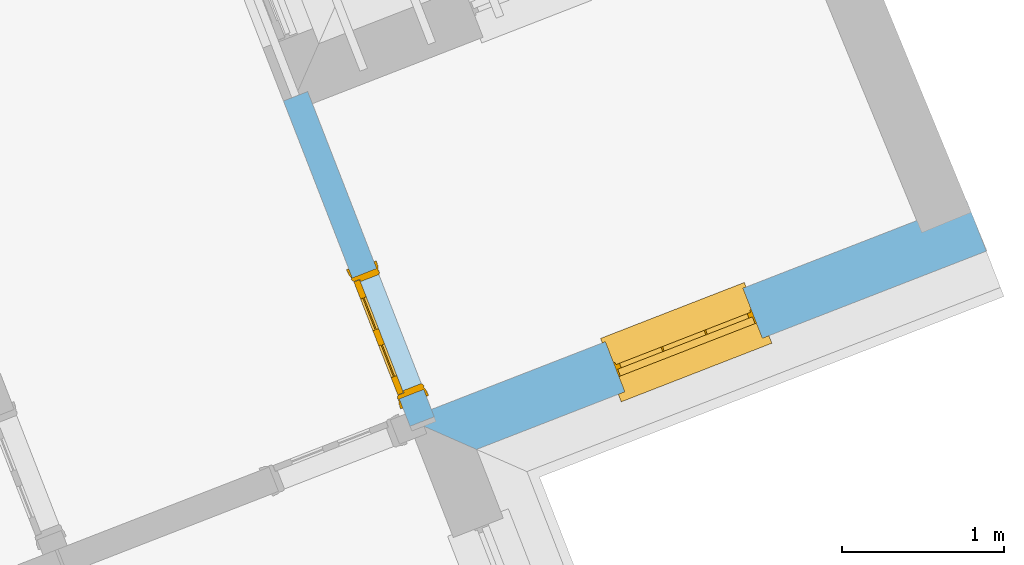
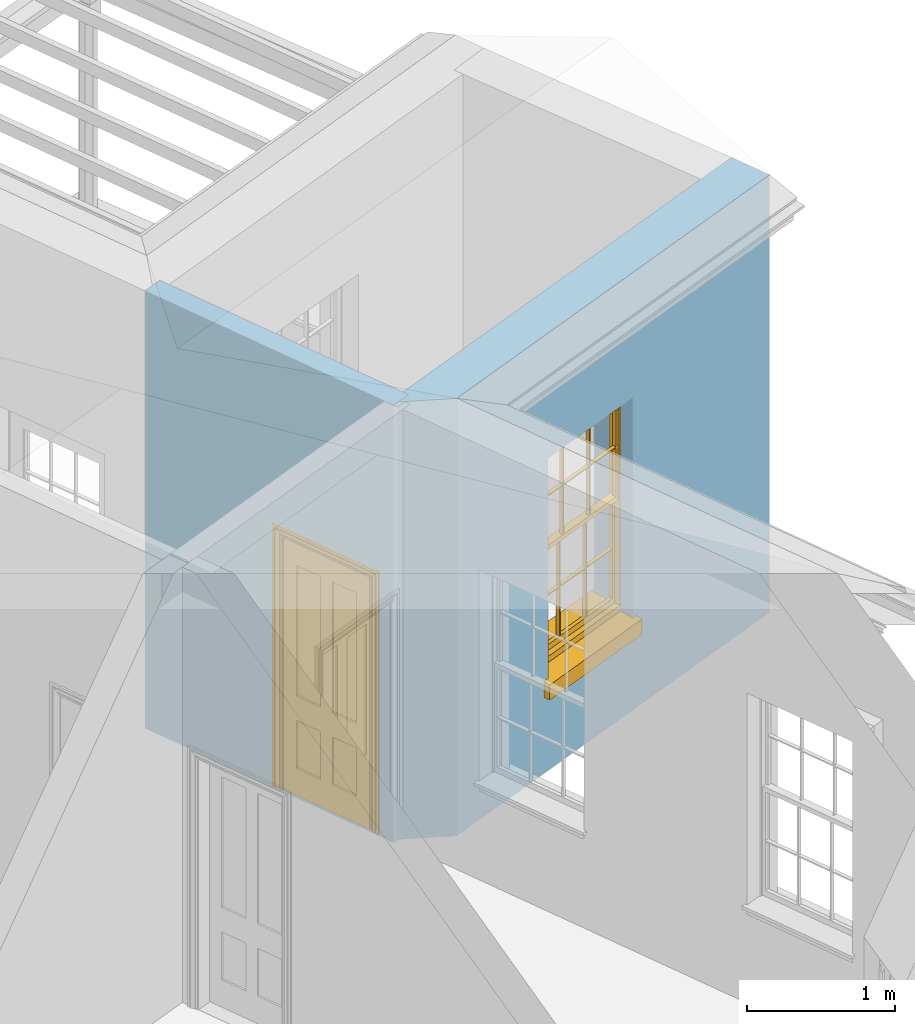
# One storey, part 7 of 11: 1 door, 1 window, 2 openings, plus 2 elements that do not belong to this part.
"""IFC2X3 building model written with IfcOpenShell, lengths in metres."""

from ifc_helpers import new_model, si_unit, frame, origin, place, context, subcontext, project, spatial, polyline, outline, extrude, faceted_brep, material, layer, layer_set, layer_usage, element, fill, save


model = new_model("IFC2X3")

# Units and contexts
model_context = context("Model", 3, world=origin())
body_context = subcontext(model_context, "Body", "Model", "MODEL_VIEW")
ifc_project = project(units=[si_unit("PLANEANGLEUNIT", "RADIAN"), si_unit("MASSUNIT", "GRAM", prefix="KILO"), si_unit("FORCEUNIT", "NEWTON", prefix="KILO"), si_unit("LENGTHUNIT", "METRE")], contexts=[model_context])

# Site, building, storey
site_placement = place(None, origin())
site = spatial("IfcSite", under=ifc_project, at=site_placement, CompositionType="ELEMENT")
building_placement = place(None, origin())
building = spatial("IfcBuilding", under=site, at=building_placement, Name="Building plot-3", CompositionType="ELEMENT")
storey_placement = place(None, frame((0.0, 0.0, 5.45)))
storey = spatial("IfcBuildingStorey", under=building, at=storey_placement, Name="Floor 1", CompositionType="ELEMENT", Elevation=5.45)

# Wall, opening, window
ifc_material_1 = material(Name="Masonry")
ifc_layer_1 = layer(ifc_material_1, 0.33, ventilated=False)
ifc_layer_set_1 = layer_set([ifc_layer_1], Name="My Wall")
ifc_layer_usage_1 = layer_usage(ifc_layer_set_1, "AXIS2", "NEGATIVE", 0.08)
wall_1_placement = place(storey_placement, origin())
wall_1 = element("IfcWallStandardCase", 1, at=wall_1_placement, inside=storey, material=ifc_layer_usage_1, Name="exterior", context=body_context, shape_type="SweptSolid", body=[
    extrude(outline(polyline([(41.1667504349144, 48.3334570792536), (41.5939403189539, 48.1455507116809), (44.7327190868894, 49.3665921650056), (44.613077328656, 49.6741402908117), (41.1667504349144, 48.3334570792536)])), origin(), (0.0, 0.0, 1.0), 3.6),
])
opening_1_placement = place(storey_placement, frame((0.0, 0.0, 0.75)))
opening_1 = element("IfcOpeningElement", 2, at=opening_1_placement, cuts=wall_1, Name="Opening", ObjectType="Opening", context=body_context, shape_type="SweptSolid", body=[
    extrude(outline(polyline([(42.5062950705178, 48.5004731366628), (43.3543823265284, 48.830394348761), (43.234740568295, 49.1379424745671), (42.3866533122844, 48.8080212624689), (42.5062950705178, 48.5004731366628)])), origin(), (0.0, 0.0, 1.0), 1.82),
])
window_placement = place(storey_placement, frame((42.4156573748864, 48.7334641410613, 0.75), z_axis=(0.0, 0.0, 1.0), x_axis=(0.848087256010643, 0.329921212098206, 0.0)))
window = element("IfcWindow", 3, at=window_placement, inside=storey, Name="toilet outside window", OverallHeight=1.82, OverallWidth=0.91, context=body_context, shape_type="Brep", held_by="IfcProductRepresentation", body=[
    faceted_brep([(0.033125, -0.105, 0.975209), (0.01, -0.105, 0.975209), (0.033125, -0.105, 1.376042), (0.876875, -0.105, 0.975209), (0.876875, -0.105, 1.376042), (0.9, -0.105, 0.975209), (0.876875, -0.105, 1.386042), (0.876875, -0.105, 1.786875), (0.9, -0.105, 1.81), (0.033125, -0.105, 1.786875), (0.033125, -0.105, 1.386042), (0.01, -0.105, 1.81), (0.876875, -0.135, 1.376042), (0.876875, -0.135, 0.975209), (0.9, -0.135, 0.937083), (0.033125, -0.135, 1.786875), (0.01, -0.135, 1.81), (0.033125, -0.135, 1.386042), (0.01, -0.135, 0.937083), (0.033125, -0.135, 0.975209), (0.033125, -0.135, 1.376042), (0.876875, -0.135, 1.786875), (0.876875, -0.135, 1.386042), (0.9, -0.135, 1.81), (0.033125, -0.105, 0.937083), (0.01, -0.105, 0.937083), (0.033125, -0.105, 0.53625), (0.876875, -0.105, 0.937083), (0.876875, -0.105, 0.53625), (0.9, -0.105, 0.937083), (0.876875, -0.105, 0.52625), (0.876875, -0.105, 0.125417), (0.9, -0.105, 0.077167), (0.033125, -0.105, 0.125417), (0.033125, -0.105, 0.52625), (0.01, -0.105, 0.077167), (-0.0425, -0.25, 0.01), (-0.0425, -0.3, 0.001667), (0.0, -0.25, 0.01), (0.9525, -0.25, 0.01), (0.91, -0.25, 0.01), (0.9525, -0.3, 0.001667), (-0.02, 0.08, 0.077167), (0.0, 0.08, 0.077167), (-0.02, 0.11, 0.077167), (0.0, -0.06, 0.077167), (0.01, -0.06, 0.077167), (0.91, -0.06, 0.077167), (0.91, 0.08, 0.077167), (0.9, -0.06, 0.077167), (0.93, 0.08, 0.077167), (0.93, 0.11, 0.077167), (0.01, -0.075, 0.975209), (0.9, -0.075, 0.975209), (0.876875, -0.075, 0.125417), (0.876875, -0.075, 0.52625), (0.9, -0.075, 0.077167), (0.876875, -0.075, 0.53625), (0.876875, -0.075, 0.937083), (0.033125, -0.075, 0.125417), (0.01, -0.075, 0.077167), (0.033125, -0.075, 0.52625), (0.033125, -0.075, 0.937083), (0.033125, -0.075, 0.53625), (-0.02, 0.08, 0.052167), (-0.02, 0.11, 0.052167), (0.93, 0.11, 0.052167), (0.93, 0.08, 0.052167), (0.91, 0.08, 0.052167), (0.0, 0.08, 0.052167), (0.91, -0.15, 0.026667), (0.0, -0.15, 0.026667), (-0.0425, -0.3, -0.123333), (0.9525, -0.3, -0.123333), (-0.0425, -0.25, -0.123333), (0.9525, -0.25, -0.123333), (0.01, -0.06, 1.81), (0.9, -0.06, 1.81), (0.0, -0.06, 1.82), (0.91, -0.06, 1.82), (0.01, -0.15, 0.077167), (0.9, -0.15, 0.077167), (0.592292, -0.105, 0.125417), (0.592292, -0.075, 0.125417), (0.317708, -0.075, 0.125417), (0.317708, -0.105, 0.125417), (0.592292, -0.105, 0.53625), (0.317708, -0.105, 0.53625), (0.317708, -0.105, 0.52625), (0.592292, -0.105, 0.52625), (0.592292, -0.075, 0.53625), (0.317708, -0.075, 0.53625), (0.592292, -0.135, 1.386042), (0.592292, -0.105, 1.386042), (0.317708, -0.105, 1.386042), (0.317708, -0.135, 1.386042), (0.317708, -0.135, 1.376042), (0.592292, -0.135, 1.376042), (0.317708, -0.105, 1.376042), (0.592292, -0.105, 1.376042), (0.602292, -0.135, 1.376042), (0.592292, -0.135, 0.975209), (0.602292, -0.135, 0.975209), (0.602292, -0.105, 0.975209), (0.592292, -0.105, 0.975209), (0.602292, -0.105, 1.376042), (0.602292, -0.075, 0.53625), (0.602292, -0.105, 0.53625), (0.317708, -0.075, 0.52625), (0.307708, -0.075, 0.125417), (0.307708, -0.075, 0.52625), (0.602292, -0.075, 0.52625), (0.602292, -0.075, 0.125417), (0.592292, -0.075, 0.52625), (0.307708, -0.075, 0.53625), (0.317708, -0.075, 0.937083), (0.307708, -0.075, 0.937083), (0.602292, -0.075, 0.937083), (0.592292, -0.075, 0.937083), (0.307708, -0.105, 0.52625), (0.307708, -0.105, 0.125417), (0.307708, -0.105, 0.53625), (0.307708, -0.105, 0.937083), (0.592292, -0.105, 0.937083), (0.317708, -0.105, 0.937083), (0.602292, -0.105, 0.937083), (0.602292, -0.105, 0.52625), (0.602292, -0.105, 0.125417), (0.307708, -0.135, 1.386042), (0.307708, -0.135, 1.376042), (0.307708, -0.135, 0.975209), (0.317708, -0.135, 0.975209), (0.317708, -0.135, 1.786875), (0.307708, -0.135, 1.786875), (0.602292, -0.135, 1.786875), (0.592292, -0.135, 1.786875), (0.602292, -0.135, 1.386042), (0.602292, -0.105, 1.386042), (0.307708, -0.105, 1.386042), (0.307708, -0.105, 1.786875), (0.317708, -0.105, 1.786875), (0.592292, -0.105, 1.786875), (0.602292, -0.105, 1.786875), (0.307708, -0.105, 1.376042), (0.317708, -0.105, 0.975209), (0.307708, -0.105, 0.975209), (0.91, -0.15, 1.82), (0.9, -0.15, 1.81), (0.01, -0.15, 1.81), (0.0, -0.15, 1.82), (0.91, -0.25, 0.0), (0.0, -0.25, 0.0), (0.91, 0.08, 0.0), (0.0, 0.08, 0.0)], [[[0, 1, 2]], [[3, 4, 5]], [[6, 7, 8]], [[9, 10, 11]], [[12, 13, 14]], [[15, 16, 17]], [[18, 19, 20]], [[21, 22, 23]], [[24, 25, 26]], [[27, 28, 29]], [[30, 31, 32]], [[33, 34, 35]], [[14, 27, 29]], [[25, 24, 18]], [[36, 37, 38]], [[39, 40, 41]], [[42, 43, 44]], [[45, 46, 43]], [[47, 48, 49]], [[50, 51, 48]], [[1, 0, 52]], [[5, 53, 3]], [[54, 55, 56]], [[57, 58, 53]], [[59, 60, 61]], [[62, 63, 52]], [[48, 43, 46, 49]], [[51, 44, 43, 48]], [[64, 42, 44, 65]], [[65, 44, 51, 66]], [[66, 51, 50, 67]], [[65, 66, 68, 69]], [[60, 56, 49, 46]], [[70, 71, 38, 40]], [[37, 41, 40, 38]], [[37, 72, 73, 41]], [[74, 75, 73, 72]], [[8, 11, 76, 77]], [[76, 78, 79, 77]], [[32, 35, 80, 81]], [[81, 80, 71, 70]], [[82, 83, 84, 85]], [[86, 87, 88, 89]], [[86, 90, 91, 87]], [[92, 93, 94, 95]], [[92, 95, 96, 97]], [[96, 98, 99, 97]], [[100, 97, 101, 102]], [[103, 104, 99, 105]], [[97, 99, 104, 101]], [[102, 103, 105, 100]], [[28, 57, 106, 107]], [[108, 84, 109, 110]], [[111, 112, 83, 113]], [[114, 110, 61, 63]], [[90, 113, 108, 91]], [[115, 91, 114, 116]], [[117, 106, 90, 118]], [[111, 106, 57, 55]], [[119, 110, 109, 120]], [[34, 61, 110, 119]], [[89, 113, 83, 82]], [[88, 108, 113, 89]], [[85, 84, 108, 88]], [[121, 114, 63, 26]], [[122, 116, 114, 121]], [[123, 118, 90, 86]], [[87, 91, 115, 124]], [[107, 106, 117, 125]], [[126, 111, 55, 30]], [[127, 112, 111, 126]], [[126, 30, 28, 107]], [[88, 119, 120, 85]], [[126, 89, 82, 127]], [[125, 123, 86, 107]], [[121, 26, 34, 119]], [[124, 122, 121, 87]], [[128, 17, 20, 129]], [[96, 129, 130, 131]], [[132, 133, 128, 95]], [[134, 135, 92, 136]], [[100, 12, 22, 136]], [[137, 6, 4, 105]], [[94, 138, 139, 140]], [[137, 93, 141, 142]], [[99, 98, 94, 93]], [[143, 2, 10, 138]], [[144, 145, 143, 98]], [[129, 143, 145, 130]], [[20, 2, 143, 129]], [[131, 144, 98, 96]], [[128, 138, 10, 17]], [[133, 139, 138, 128]], [[135, 141, 93, 92]], [[95, 94, 140, 132]], [[22, 6, 137, 136]], [[136, 137, 142, 134]], [[100, 105, 4, 12]], [[107, 86, 89, 126]], [[106, 111, 113, 90]], [[91, 108, 110, 114]], [[87, 121, 119, 88]], [[97, 100, 136, 92]], [[129, 96, 95, 128]], [[98, 143, 138, 94]], [[105, 99, 93, 137]], [[131, 101, 104, 144]], [[124, 115, 118, 123]], [[132, 140, 141, 135]], [[120, 109, 59, 33]], [[15, 9, 139, 133]], [[134, 142, 7, 21]], [[31, 54, 112, 127]], [[36, 74, 72, 37]], [[39, 41, 73, 75]], [[18, 14, 101, 131]], [[23, 16, 132, 135]], [[83, 56, 60, 84]], [[52, 53, 118, 115]], [[53, 52, 144, 104]], [[11, 8, 141, 140]], [[14, 18, 124, 123]], [[2, 1, 11, 10]], [[8, 5, 4, 6]], [[57, 53, 56, 55]], [[60, 52, 63, 61]], [[26, 25, 35, 34]], [[32, 29, 28, 30]], [[14, 23, 22, 12]], [[18, 20, 17, 16]], [[19, 0, 2, 20]], [[17, 10, 9, 15]], [[12, 4, 3, 13]], [[21, 7, 6, 22]], [[27, 58, 57, 28]], [[30, 55, 54, 31]], [[33, 59, 61, 34]], [[26, 63, 62, 24]], [[5, 8, 77, 53]], [[76, 11, 1, 52]], [[46, 45, 78, 76]], [[49, 77, 79, 47]], [[70, 146, 147, 81]], [[71, 80, 148, 149]], [[19, 130, 145, 0]], [[102, 13, 3, 103]], [[116, 122, 24, 62]], [[29, 32, 81, 14]], [[80, 35, 25, 18]], [[60, 46, 76, 52]], [[77, 49, 56, 53]], [[23, 14, 81, 147]], [[16, 148, 80, 18]], [[35, 85, 120]], [[120, 33, 35]], [[127, 82, 32]], [[32, 31, 127]], [[32, 82, 85, 35]], [[102, 101, 14]], [[14, 13, 102]], [[18, 131, 130]], [[130, 19, 18]], [[134, 21, 23]], [[23, 135, 134]], [[16, 15, 133]], [[133, 132, 16]], [[11, 140, 139]], [[139, 9, 11]], [[142, 141, 8]], [[8, 7, 142]], [[23, 147, 148, 16]], [[146, 149, 148, 147]], [[52, 115, 116]], [[116, 62, 52]], [[118, 53, 117]], [[58, 117, 53]], [[27, 125, 117, 58]], [[56, 83, 112]], [[112, 54, 56]], [[109, 84, 60]], [[60, 59, 109]], [[125, 27, 14]], [[14, 123, 125]], [[122, 124, 18]], [[18, 24, 122]], [[145, 144, 52]], [[52, 0, 145]], [[103, 3, 53]], [[53, 104, 103]], [[79, 78, 149, 146]], [[78, 45, 71, 149]], [[146, 70, 47, 79]], [[150, 75, 74, 151]], [[68, 66, 67]], [[48, 68, 67, 50]], [[69, 64, 65]], [[42, 64, 69, 43]], [[69, 68, 152, 153]], [[70, 68, 48, 47]], [[150, 152, 68, 70]], [[43, 69, 71, 45]], [[69, 153, 151, 71]], [[152, 150, 151, 153]], [[38, 151, 74, 36]], [[71, 151, 38]], [[39, 75, 150, 40]], [[40, 150, 70]]]),
])
fill(opening_1, window)

# Wall, opening, door
ifc_material_2 = material(Name="Masonry")
ifc_layer_2 = layer(ifc_material_2, 0.16, ventilated=False)
ifc_layer_set_2 = layer_set([ifc_layer_2], Name="My Wall")
ifc_layer_usage_2 = layer_usage(ifc_layer_set_2, "AXIS2", "NEGATIVE", 0.08)
wall_2_placement = place(storey_placement, origin())
wall_2 = element("IfcWallStandardCase", 4, at=wall_2_placement, inside=storey, material=ifc_layer_usage_2, Name="interior", context=body_context, shape_type="SweptSolid", body=[
    extrude(outline(polyline([(41.1843450774817, 48.2882287290048), (41.3334593202967, 48.3462368542088), (40.5544755172075, 50.3486732293578), (40.4053612743925, 50.2906651041538), (41.1843450774817, 48.2882287290048)])), origin(), (0.0, 0.0, 1.0), 3.6),
])
opening_2_placement = place(storey_placement, frame((0.0, 0.0, 0.0199999999999996)))
opening_2 = element("IfcOpeningElement", 5, at=opening_2_placement, cuts=wall_2, Name="Opening", ObjectType="Opening", context=body_context, shape_type="SweptSolid", body=[
    extrude(outline(polyline([(41.2682001794421, 48.5139903773758), (40.9781595534218, 49.2595615914511), (40.8290453106067, 49.201553466247), (41.1190859366271, 48.4559822521717), (41.2682001794421, 48.5139903773758)])), origin(), (0.0, 0.0, 1.0), 2.1),
])
door_placement = place(storey_placement, frame((41.1936430580346, 48.4849863147737, 0.0199999999999996), z_axis=(0.0, 0.0, 1.0), x_axis=(-0.290040626020385, 0.745571214075291, 0.0)))
door = element("IfcDoor", 6, at=door_placement, inside=storey, Name="toilet inside door", OverallHeight=2.1, OverallWidth=0.8, context=body_context, shape_type="Brep", held_by="IfcProductRepresentation", body=[
    faceted_brep([(0.773, 0.08, 1.895), (0.66, 0.08, 1.895), (0.66, 0.08, 2.073), (0.773, 0.08, 2.073), (0.773, 0.08, 0.82), (0.66, 0.08, 0.82), (0.45, 0.08, 1.895), (0.45, 0.08, 2.073), (0.773, 0.08, 0.62), (0.66, 0.08, 0.62), (0.66, 0.065, 0.82), (0.66, 0.065, 1.895), (0.45, 0.065, 1.895), (0.35, 0.08, 1.895), (0.35, 0.08, 2.073), (0.773, 0.08, 0.225), (0.66, 0.08, 0.225), (0.45, 0.08, 0.62), (0.45, 0.08, 0.82), (0.45, 0.065, 0.82), (0.35, 0.08, 0.82), (0.14, 0.08, 2.073), (0.14, 0.08, 1.895), (0.773, 0.08, 0.0), (0.66, 0.08, 0.0), (0.66, 0.065, 0.225), (0.66, 0.065, 0.62), (0.45, 0.065, 0.62), (0.35, 0.08, 0.62), (0.35, 0.065, 0.82), (0.35, 0.065, 1.895), (0.14, 0.065, 1.895), (0.027, 0.08, 2.073), (0.027, 0.08, 1.895), (0.773, 0.042, 0.0), (0.66, 0.042, 0.0), (0.45, 0.08, 0.0), (0.45, 0.08, 0.225), (0.45, 0.065, 0.225), (0.35, 0.08, 0.225), (0.14, 0.08, 0.82), (0.14, 0.08, 0.62), (0.14, 0.065, 0.82), (0.027, 0.08, 0.82), (0.773, 0.042, 0.225), (0.66, 0.042, 0.225), (0.45, 0.042, 0.0), (0.35, 0.08, 0.0), (0.35, 0.065, 0.225), (0.35, 0.065, 0.62), (0.14, 0.065, 0.62), (0.027, 0.08, 0.62), (0.773, 0.042, 0.62), (0.66, 0.042, 0.62), (0.45, 0.042, 0.225), (0.35, 0.042, 0.0), (0.14, 0.08, 0.225), (0.14, 0.08, 0.0), (0.14, 0.065, 0.225), (0.027, 0.08, 0.225), (0.773, 0.042, 0.82), (0.66, 0.042, 0.82), (0.66, 0.057, 0.62), (0.66, 0.057, 0.225), (0.45, 0.057, 0.225), (0.35, 0.042, 0.225), (0.14, 0.042, 0.0), (0.027, 0.08, 0.0), (0.773, 0.042, 1.895), (0.66, 0.042, 1.895), (0.45, 0.042, 0.62), (0.45, 0.042, 0.82), (0.45, 0.057, 0.62), (0.35, 0.042, 0.62), (0.14, 0.042, 0.225), (0.027, 0.042, 0.0), (0.773, 0.042, 2.073), (0.66, 0.042, 2.073), (0.66, 0.057, 1.895), (0.66, 0.057, 0.82), (0.45, 0.057, 0.82), (0.35, 0.042, 0.82), (0.35, 0.057, 0.62), (0.35, 0.057, 0.225), (0.14, 0.057, 0.225), (0.027, 0.042, 0.225), (0.45, 0.042, 1.895), (0.45, 0.042, 2.073), (0.45, 0.057, 1.895), (0.35, 0.042, 1.895), (0.14, 0.042, 0.82), (0.14, 0.042, 0.62), (0.14, 0.057, 0.62), (0.027, 0.042, 0.62), (0.35, 0.042, 2.073), (0.35, 0.057, 1.895), (0.35, 0.057, 0.82), (0.14, 0.057, 0.82), (0.027, 0.042, 0.82), (0.14, 0.042, 2.073), (0.14, 0.042, 1.895), (0.14, 0.057, 1.895), (0.027, 0.042, 1.895), (0.027, 0.042, 2.073), (0.02, 0.085, 0.0), (0.005, 0.09, 0.0), (0.005, 0.09, 2.095), (0.02, 0.085, 2.08), (0.02, 0.08, 0.0), (0.0, 0.085, 0.0), (0.0, 0.085, 2.1), (0.795, 0.09, 2.095), (0.78, 0.085, 2.08), (0.02, 0.08, 2.08), (0.0, 0.08, 0.0), (-0.032, 0.095, 0.0), (-0.032, 0.095, 2.132), (0.8, 0.085, 2.1), (0.795, 0.09, 0.0), (0.78, 0.085, 0.0), (0.78, 0.08, 2.08), (0.04, 0.04, 0.0), (0.025, 0.04, 0.0), (0.025, 0.04, 2.075), (0.04, 0.04, 2.06), (-0.04, 0.09, 0.0), (-0.04, 0.09, 2.14), (0.832, 0.095, 2.132), (0.8, 0.085, 0.0), (0.78, 0.08, 0.0), (0.8, 0.08, 0.0), (0.86, 0.08, 0.0), (0.86, 0.08, 2.16), (0.8, 0.08, 2.1), (-0.06, 0.08, 2.16), (0.0, 0.08, 2.1), (-0.06, 0.08, 0.0), (-0.04, 0.095, 0.0), (-0.04, 0.095, 2.14), (0.84, 0.09, 2.14), (0.832, 0.095, 0.0), (0.84, 0.09, 0.0), (0.86, 0.095, 0.0), (0.86, 0.095, 2.16), (-0.06, 0.095, 2.16), (-0.06, 0.095, 0.0), (0.84, 0.095, 0.0), (0.84, 0.095, 2.14), (-0.025, -0.095, 0.0), (-0.025, -0.09, 0.0), (-0.025, -0.09, 2.125), (-0.025, -0.095, 2.125), (-0.017, -0.095, 0.0), (-0.017, -0.095, 2.117), (0.825, -0.09, 2.125), (0.825, -0.095, 2.125), (0.825, -0.095, 0.0), (0.845, -0.095, 0.0), (-0.045, -0.095, 2.145), (-0.045, -0.095, 0.0), (0.845, -0.095, 2.145), (0.015, -0.085, 0.0), (0.015, -0.085, 2.085), (0.817, -0.095, 2.117), (0.825, -0.09, 0.0), (0.845, -0.08, 0.0), (0.845, -0.08, 2.145), (-0.045, -0.08, 2.145), (-0.045, -0.08, 0.0), (0.02, -0.09, 0.0), (0.02, -0.09, 2.08), (0.785, -0.085, 2.085), (0.817, -0.095, 0.0), (0.8, -0.08, 0.0), (0.8, -0.08, 2.1), (0.0, -0.08, 2.1), (0.0, -0.08, 0.0), (0.035, -0.085, 0.0), (0.035, -0.085, 2.065), (0.78, -0.09, 2.08), (0.785, -0.085, 0.0), (0.775, 0.04, 2.075), (0.76, 0.04, 2.06), (0.035, -0.08, 2.065), (0.035, -0.08, 0.0), (0.765, -0.085, 2.065), (0.78, -0.09, 0.0), (0.765, -0.08, 0.0), (0.765, -0.08, 2.065), (0.765, -0.085, 0.0), (0.04, -0.08, 2.06), (0.04, -0.08, 0.0), (0.76, -0.08, 2.06), (0.76, -0.08, 0.0), (0.76, 0.04, 0.0), (0.775, 0.04, 0.0), (0.025, 0.08, 0.0), (0.025, 0.08, 2.075), (0.775, 0.08, 0.0), (0.775, 0.08, 2.075)], [[[0, 1, 2, 3]], [[1, 0, 4, 5]], [[1, 6, 7, 2]], [[8, 9, 5, 4]], [[1, 5, 10, 11]], [[6, 1, 11, 12]], [[6, 13, 14, 7]], [[15, 16, 9, 8]], [[9, 17, 18, 5]], [[5, 18, 19, 10]], [[10, 19, 12, 11]], [[18, 6, 12, 19]], [[18, 20, 13, 6]], [[21, 14, 13, 22]], [[23, 24, 16, 15]], [[9, 16, 25, 26]], [[17, 9, 26, 27]], [[17, 28, 20, 18]], [[13, 20, 29, 30]], [[22, 13, 30, 31]], [[32, 21, 22, 33]], [[34, 35, 24, 23]], [[24, 36, 37, 16]], [[16, 37, 38, 25]], [[25, 38, 27, 26]], [[37, 17, 27, 38]], [[37, 39, 28, 17]], [[40, 20, 28, 41]], [[20, 40, 42, 29]], [[31, 30, 29, 42]], [[40, 22, 31, 42]], [[33, 22, 40, 43]], [[35, 34, 44, 45]], [[35, 46, 36, 24]], [[36, 47, 39, 37]], [[28, 39, 48, 49]], [[41, 28, 49, 50]], [[43, 40, 41, 51]], [[45, 44, 52, 53]], [[46, 35, 45, 54]], [[46, 55, 47, 36]], [[56, 39, 47, 57]], [[39, 56, 58, 48]], [[50, 49, 48, 58]], [[56, 41, 50, 58]], [[51, 41, 56, 59]], [[53, 52, 60, 61]], [[45, 53, 62, 63]], [[54, 45, 63, 64]], [[55, 46, 54, 65]], [[55, 66, 57, 47]], [[59, 56, 57, 67]], [[61, 60, 68, 69]], [[70, 53, 61, 71]], [[53, 70, 72, 62]], [[72, 64, 63, 62]], [[70, 54, 64, 72]], [[65, 54, 70, 73]], [[65, 74, 66, 55]], [[67, 57, 66, 75]], [[69, 68, 76, 77]], [[61, 69, 78, 79]], [[71, 61, 79, 80]], [[73, 70, 71, 81]], [[65, 73, 82, 83]], [[74, 65, 83, 84]], [[74, 85, 75, 66]], [[86, 69, 77, 87]], [[69, 86, 88, 78]], [[88, 80, 79, 78]], [[86, 71, 80, 88]], [[81, 71, 86, 89]], [[73, 81, 90, 91]], [[73, 91, 92, 82]], [[83, 82, 92, 84]], [[91, 74, 84, 92]], [[91, 93, 85, 74]], [[89, 86, 87, 94]], [[81, 89, 95, 96]], [[90, 81, 96, 97]], [[90, 98, 93, 91]], [[94, 99, 100, 89]], [[89, 100, 101, 95]], [[101, 97, 96, 95]], [[100, 90, 97, 101]], [[100, 102, 98, 90]], [[99, 103, 102, 100]], [[32, 103, 99, 21]], [[102, 103, 32, 33]], [[98, 102, 33, 43]], [[21, 99, 94, 14]], [[94, 87, 7, 14]], [[7, 87, 77, 2]], [[76, 3, 2, 77]], [[43, 51, 93, 98]], [[51, 59, 85, 93]], [[67, 75, 85, 59]], [[34, 23, 15, 44]], [[44, 15, 8, 52]], [[52, 8, 4, 60]], [[0, 68, 60, 4]], [[0, 3, 76, 68]], [[104, 105, 106, 107]], [[104, 108, 109, 105]], [[105, 109, 110, 106]], [[107, 106, 111, 112]], [[107, 113, 108, 104]], [[114, 109, 108]], [[109, 115, 116, 110]], [[106, 110, 117, 111]], [[112, 111, 118, 119]], [[113, 107, 112, 120]], [[121, 122, 123, 124]], [[115, 109, 114, 125]], [[115, 125, 126, 116]], [[110, 116, 127, 117]], [[111, 117, 128, 118]], [[118, 128, 129, 119]], [[120, 112, 119, 129]], [[130, 129, 128]], [[130, 131, 132, 133]], [[133, 132, 134, 135]], [[135, 134, 136, 114]], [[136, 125, 114]], [[125, 137, 138, 126]], [[116, 126, 139, 127]], [[117, 127, 140, 128]], [[141, 130, 128, 140]], [[131, 130, 141]], [[131, 142, 143, 132]], [[132, 143, 144, 134]], [[134, 144, 145, 136]], [[137, 125, 136, 145]], [[143, 142, 146]], [[143, 146, 147]], [[137, 145, 144]], [[143, 147, 138]], [[138, 137, 144]], [[143, 138, 144]], [[126, 138, 147, 139]], [[127, 139, 141, 140]], [[142, 131, 141, 146]], [[139, 147, 146, 141]], [[148, 149, 150, 151]], [[149, 152, 153, 150]], [[151, 150, 154, 155]], [[155, 156, 157]], [[158, 159, 148]], [[158, 148, 151]], [[155, 157, 160]], [[158, 151, 155]], [[155, 160, 158]], [[152, 161, 162, 153]], [[150, 153, 163, 154]], [[155, 154, 164, 156]], [[156, 164, 165, 157]], [[157, 165, 166, 160]], [[160, 166, 167, 158]], [[158, 167, 168, 159]], [[161, 169, 170, 162]], [[153, 162, 171, 163]], [[154, 163, 172, 164]], [[165, 164, 173]], [[165, 173, 174, 166]], [[166, 174, 175, 167]], [[167, 175, 176, 168]], [[169, 177, 178, 170]], [[162, 170, 179, 171]], [[163, 171, 180, 172]], [[172, 180, 173, 164]], [[124, 123, 181, 182]], [[183, 178, 177, 184]], [[170, 178, 185, 179]], [[171, 179, 186, 180]], [[187, 173, 180]], [[185, 188, 187, 189]], [[188, 185, 178, 183]], [[179, 185, 189, 186]], [[189, 187, 180, 186]], [[190, 183, 184, 191]], [[192, 188, 183, 190]], [[191, 184, 122, 121]], [[124, 190, 191, 121]], [[193, 187, 188, 192]], [[182, 192, 190, 124]], [[184, 176, 122]], [[194, 195, 187, 193]], [[192, 182, 194, 193]], [[161, 176, 184]], [[114, 108, 122, 176]], [[173, 187, 195]], [[152, 149, 176, 161]], [[169, 161, 184, 177]], [[196, 122, 108]], [[176, 175, 135, 114]], [[173, 195, 129, 130]], [[176, 149, 168]], [[123, 122, 196, 197]], [[196, 108, 113, 197]], [[175, 174, 133, 135]], [[198, 129, 195]], [[133, 174, 173, 130]], [[159, 168, 149, 148]], [[181, 123, 197, 199]], [[197, 113, 120, 199]], [[199, 120, 129, 198]], [[195, 181, 199, 198]], [[195, 194, 182, 181]]]),
])
fill(opening_2, door)

save(model, "model.ifc")
